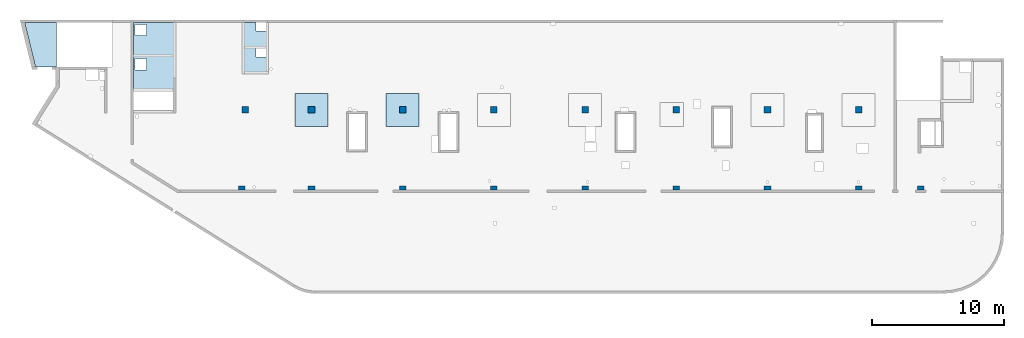
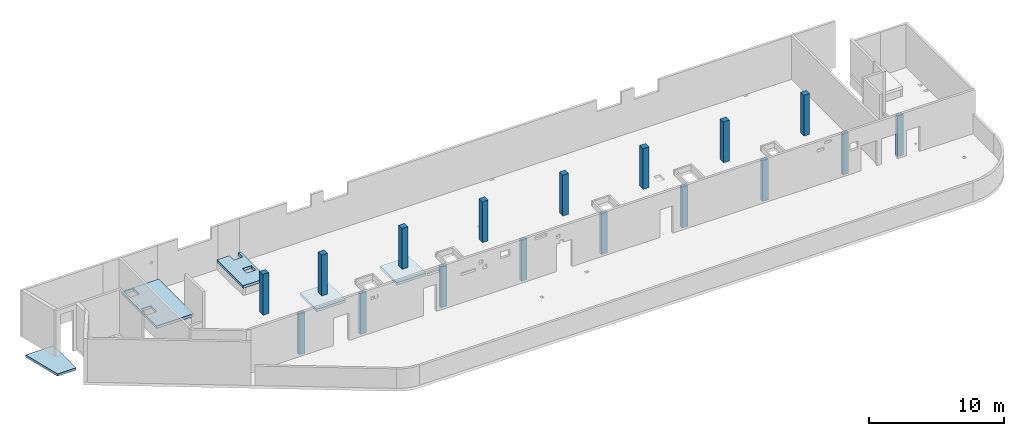
# One storey, part 1 of 6: 17 columns, 5 slabs.
"""IFC4 building model written with IfcOpenShell, lengths in millimetres."""

from ifc_helpers import new_model, entity, si_unit, converted_unit, derived_unit, direction, frame, origin, place, context, subcontext, project, spatial, indexed_curve, outline, extrude, source, transform, mapped, material, type_object, type_shapes, element, save


model = new_model("IFC4")

# Units and contexts
model_context = context("Model", 3, precision=0.01, world=origin(), true_north=direction((6.12303176911189e-17, 1.0)))
plan_context = context("Plan", 3, precision=0.01, world=origin(), true_north=direction((6.12303176911189e-17, 1.0)))
body_context = subcontext(model_context, "Body", "Model", "MODEL_VIEW")
ifc_project = project(units=[si_unit("LENGTHUNIT", "METRE", prefix="MILLI"), si_unit("AREAUNIT", "SQUARE_METRE"), si_unit("VOLUMEUNIT", "CUBIC_METRE"), converted_unit("PLANEANGLEUNIT", "DEGREE", entity("IfcRatioMeasure", 0.0174532925199433), si_unit("PLANEANGLEUNIT", "RADIAN"), dimensions=[0, 0, 0, 0, 0, 0, 0]), si_unit("MASSUNIT", "GRAM", prefix="KILO"), derived_unit("MASSDENSITYUNIT", [(si_unit("MASSUNIT", "GRAM", prefix="KILO"), 1), (si_unit("LENGTHUNIT", "METRE"), -3)]), derived_unit("MOMENTOFINERTIAUNIT", [(si_unit("LENGTHUNIT", "METRE"), 4)]), si_unit("TIMEUNIT", "SECOND"), si_unit("FREQUENCYUNIT", "HERTZ"), si_unit("THERMODYNAMICTEMPERATUREUNIT", "DEGREE_CELSIUS"), derived_unit("THERMALTRANSMITTANCEUNIT", [(si_unit("MASSUNIT", "GRAM", prefix="KILO"), 1), (si_unit("THERMODYNAMICTEMPERATUREUNIT", "KELVIN"), -1), (si_unit("TIMEUNIT", "SECOND"), -3)]), derived_unit("VOLUMETRICFLOWRATEUNIT", [(si_unit("LENGTHUNIT", "METRE"), 3), (si_unit("TIMEUNIT", "SECOND"), -1)]), derived_unit("MASSFLOWRATEUNIT", [(si_unit("MASSUNIT", "GRAM", prefix="KILO"), 1), (si_unit("TIMEUNIT", "SECOND"), -1)]), derived_unit("ROTATIONALFREQUENCYUNIT", [(si_unit("TIMEUNIT", "SECOND"), -1)]), si_unit("ELECTRICCURRENTUNIT", "AMPERE"), si_unit("ELECTRICVOLTAGEUNIT", "VOLT"), si_unit("POWERUNIT", "WATT"), si_unit("FORCEUNIT", "NEWTON", prefix="KILO"), si_unit("ILLUMINANCEUNIT", "LUX"), si_unit("LUMINOUSFLUXUNIT", "LUMEN"), si_unit("LUMINOUSINTENSITYUNIT", "CANDELA"), derived_unit("USERDEFINED", [(si_unit("MASSUNIT", "GRAM", prefix="KILO"), -1), (si_unit("LENGTHUNIT", "METRE"), -2), (si_unit("TIMEUNIT", "SECOND"), 3), (si_unit("LUMINOUSFLUXUNIT", "LUMEN"), 1)]), derived_unit("LINEARVELOCITYUNIT", [(si_unit("LENGTHUNIT", "METRE"), 1), (si_unit("TIMEUNIT", "SECOND"), -1)]), si_unit("PRESSUREUNIT", "PASCAL"), derived_unit("USERDEFINED", [(si_unit("LENGTHUNIT", "METRE"), -2), (si_unit("MASSUNIT", "GRAM", prefix="KILO"), 1), (si_unit("TIMEUNIT", "SECOND"), -2)]), derived_unit("LINEARFORCEUNIT", [(si_unit("MASSUNIT", "GRAM", prefix="KILO"), 1), (si_unit("LENGTHUNIT", "METRE"), 1), (si_unit("TIMEUNIT", "SECOND"), -2), (si_unit("LENGTHUNIT", "METRE"), -1)]), derived_unit("PLANARFORCEUNIT", [(si_unit("MASSUNIT", "GRAM", prefix="KILO"), 1), (si_unit("LENGTHUNIT", "METRE"), 1), (si_unit("TIMEUNIT", "SECOND"), -2), (si_unit("LENGTHUNIT", "METRE"), -2)])], contexts=[model_context, plan_context])

# Site, building, storey
site_placement = place(None, origin())
site = spatial("IfcSite", under=ifc_project, at=site_placement, CompositionType="ELEMENT")
building_placement = place(site_placement, origin())
building = spatial("IfcBuilding", under=site, at=building_placement, CompositionType="ELEMENT")
storey_placement = place(building_placement, frame((0.0, 0.0, 28200.0)))
storey = spatial("IfcBuildingStorey", under=building, at=storey_placement, Name="08", CompositionType="ELEMENT", Elevation=28200.0)

# Columns
ifc_material = material()
column_type_1 = type_object("IfcColumnType", PredefinedType="COLUMN", material=ifc_material)
shared_shape_1 = source(origin(), body_context, "Body", "SweptSolid", [
    extrude(outline(indexed_curve([(-149.999999999996, -249.999999999999), (149.999999999995, -249.999999999999), (149.999999999997, 249.999999999999), (-149.999999999997, 249.999999999999), (-149.999999999996, -249.999999999999)], self_intersect=False)), frame((15900.0, 7800.0, 28050.0), z_axis=(0.0, 0.0, 1.0), x_axis=(0.0, -1.0, 0.0)), (0.0, 0.0, 1.0), 3700.0),
])
type_shapes(column_type_1, [shared_shape_1])
placement_1 = place(storey_placement, frame((0.0, 0.0, -28200.0)))
element("IfcColumn", 1, at=placement_1, inside=storey, type_object=column_type_1, PredefinedType="COLUMN", context=body_context, shape_type="MappedRepresentation", body=[
    mapped(shared_shape_1, transform((0.0, 0.0, 0.0), scale=1.0)),
])
column_type_2 = type_object("IfcColumnType", PredefinedType="COLUMN", material=ifc_material)
shared_shape_2 = source(origin(), body_context, "Body", "SweptSolid", [
    extrude(outline(indexed_curve([(-149.999999999996, -249.999999999999), (149.999999999995, -249.999999999999), (149.999999999996, 249.999999999999), (-149.999999999997, 249.999999999999), (-149.999999999996, -249.999999999999)], self_intersect=False)), frame((21170.0, 7800.0, 28050.0), z_axis=(0.0, 0.0, 1.0), x_axis=(0.0, -1.0, 0.0)), (0.0, 0.0, 1.0), 3700.0),
])
type_shapes(column_type_2, [shared_shape_2])
element("IfcColumn", 2, at=placement_1, inside=storey, type_object=column_type_2, PredefinedType="COLUMN", context=body_context, shape_type="MappedRepresentation", body=[
    mapped(shared_shape_2, transform((0.0, 0.0, 0.0), scale=1.0)),
])
column_type_3 = type_object("IfcColumnType", PredefinedType="COLUMN", material=ifc_material)
shared_shape_3 = source(origin(), body_context, "Body", "SweptSolid", [
    extrude(outline(indexed_curve([(-149.999999999996, -249.999999999999), (149.999999999995, -249.999999999999), (149.999999999996, 249.999999999999), (-149.999999999996, 249.999999999999), (-149.999999999996, -249.999999999999)], self_intersect=False)), frame((28070.0, 7800.0, 28050.0), z_axis=(0.0, 0.0, 1.0), x_axis=(0.0, -1.0, 0.0)), (0.0, 0.0, 1.0), 3700.0),
])
type_shapes(column_type_3, [shared_shape_3])
element("IfcColumn", 3, at=placement_1, inside=storey, type_object=column_type_3, PredefinedType="COLUMN", context=body_context, shape_type="MappedRepresentation", body=[
    mapped(shared_shape_3, transform((0.0, 0.0, 0.0), scale=1.0)),
])
column_type_4 = type_object("IfcColumnType", PredefinedType="COLUMN", material=ifc_material)
shared_shape_4 = source(origin(), body_context, "Body", "SweptSolid", [
    extrude(outline(indexed_curve([(-149.999999999994, -249.999999999999), (149.999999999995, -249.999999999999), (149.999999999996, 249.999999999995), (-149.999999999995, 249.999999999999), (-149.999999999994, -249.999999999999)], self_intersect=False)), frame((34970.0, 7800.0, 28050.0), z_axis=(0.0, 0.0, 1.0), x_axis=(0.0, -1.0, 0.0)), (0.0, 0.0, 1.0), 3700.0),
])
type_shapes(column_type_4, [shared_shape_4])
element("IfcColumn", 4, at=placement_1, inside=storey, type_object=column_type_4, PredefinedType="COLUMN", context=body_context, shape_type="MappedRepresentation", body=[
    mapped(shared_shape_4, transform((0.0, 0.0, 0.0), scale=1.0)),
])
column_type_5 = type_object("IfcColumnType", PredefinedType="COLUMN", material=ifc_material)
shared_shape_5 = source(origin(), body_context, "Body", "SweptSolid", [
    extrude(outline(indexed_curve([(-149.999999999994, -250.000000000004), (149.999999999995, -250.000000000004), (149.999999999996, 250.000000000004), (-149.999999999994, 250.000000000004), (-149.999999999994, -250.000000000004)], self_intersect=False)), frame((41870.0, 7800.0, 28050.0), z_axis=(0.0, 0.0, 1.0), x_axis=(0.0, -1.0, 0.0)), (0.0, 0.0, 1.0), 3700.0),
])
type_shapes(column_type_5, [shared_shape_5])
element("IfcColumn", 5, at=placement_1, inside=storey, type_object=column_type_5, PredefinedType="COLUMN", context=body_context, shape_type="MappedRepresentation", body=[
    mapped(shared_shape_5, transform((0.0, 0.0, 0.0), scale=1.0)),
])
column_type_6 = type_object("IfcColumnType", PredefinedType="COLUMN", material=ifc_material)
shared_shape_6 = source(origin(), body_context, "Body", "SweptSolid", [
    extrude(outline(indexed_curve([(-149.999999999994, -250.000000000004), (149.999999999993, -250.000000000004), (149.999999999994, 250.000000000004), (-149.999999999995, 250.000000000004), (-149.999999999994, -250.000000000004)], self_intersect=False)), frame((48770.0, 7800.0, 28050.0), z_axis=(0.0, 0.0, 1.0), x_axis=(0.0, -1.0, 0.0)), (0.0, 0.0, 1.0), 3700.0),
])
type_shapes(column_type_6, [shared_shape_6])
element("IfcColumn", 6, at=placement_1, inside=storey, type_object=column_type_6, PredefinedType="COLUMN", context=body_context, shape_type="MappedRepresentation", body=[
    mapped(shared_shape_6, transform((0.0, 0.0, 0.0), scale=1.0)),
])
column_type_7 = type_object("IfcColumnType", PredefinedType="COLUMN", material=ifc_material)
shared_shape_7 = source(origin(), body_context, "Body", "SweptSolid", [
    extrude(outline(indexed_curve([(-149.999999999994, -250.000000000004), (149.999999999993, -250.000000000004), (149.999999999994, 250.000000000004), (-149.999999999994, 250.000000000004), (-149.999999999994, -250.000000000004)], self_intersect=False)), frame((55670.0, 7800.0, 28050.0), z_axis=(0.0, 0.0, 1.0), x_axis=(0.0, -1.0, 0.0)), (0.0, 0.0, 1.0), 3700.0),
])
type_shapes(column_type_7, [shared_shape_7])
element("IfcColumn", 7, at=placement_1, inside=storey, type_object=column_type_7, PredefinedType="COLUMN", context=body_context, shape_type="MappedRepresentation", body=[
    mapped(shared_shape_7, transform((0.0, 0.0, 0.0), scale=1.0)),
])
column_type_8 = type_object("IfcColumnType", PredefinedType="COLUMN", material=ifc_material)
shared_shape_8 = source(origin(), body_context, "Body", "SweptSolid", [
    extrude(outline(indexed_curve([(-149.999999999992, -250.000000000004), (149.999999999993, -250.000000000004), (149.999999999995, 250.000000000004), (-149.999999999993, 250.000000000004), (-149.999999999992, -250.000000000004)], self_intersect=False)), frame((62570.0, 7800.0, 28050.0), z_axis=(0.0, 0.0, 1.0), x_axis=(0.0, -1.0, 0.0)), (0.0, 0.0, 1.0), 3700.0),
])
type_shapes(column_type_8, [shared_shape_8])
element("IfcColumn", 8, at=placement_1, inside=storey, type_object=column_type_8, PredefinedType="COLUMN", context=body_context, shape_type="MappedRepresentation", body=[
    mapped(shared_shape_8, transform((0.0, 0.0, 0.0), scale=1.0)),
])
column_type_9 = type_object("IfcColumnType", PredefinedType="COLUMN", material=ifc_material)
shared_shape_9 = source(origin(), body_context, "Body", "SweptSolid", [
    extrude(outline(indexed_curve([(-149.999999999992, -250.000000000004), (149.999999999993, -250.000000000004), (149.999999999994, 250.000000000004), (-149.999999999993, 250.000000000004), (-149.999999999992, -250.000000000004)], self_intersect=False)), frame((67270.0, 7800.0, 28050.0), z_axis=(0.0, 0.0, 1.0), x_axis=(0.0, -1.0, 0.0)), (0.0, 0.0, 1.0), 3700.0),
])
type_shapes(column_type_9, [shared_shape_9])
element("IfcColumn", 9, at=placement_1, inside=storey, type_object=column_type_9, PredefinedType="COLUMN", context=body_context, shape_type="MappedRepresentation", body=[
    mapped(shared_shape_9, transform((0.0, 0.0, 0.0), scale=1.0)),
])
column_type_10 = type_object("IfcColumnType", PredefinedType="COLUMN", material=ifc_material)
shared_shape_10 = source(origin(), body_context, "Body", "SweptSolid", [
    extrude(outline(indexed_curve([(-249.999999999999, -250.000000000004), (249.999999999999, -250.000000000004), (249.999999999999, 249.999999999995), (-249.999999999999, 250.000000000004), (-249.999999999999, -250.000000000004)], self_intersect=False)), frame((62570.0, 13700.0, 28050.0), z_axis=(0.0, 0.0, 1.0), x_axis=(0.0, -1.0, 0.0)), (0.0, 0.0, 1.0), 3700.0),
])
type_shapes(column_type_10, [shared_shape_10])
element("IfcColumn", 10, at=placement_1, inside=storey, type_object=column_type_10, PredefinedType="COLUMN", context=body_context, shape_type="MappedRepresentation", body=[
    mapped(shared_shape_10, transform((0.0, 0.0, 0.0), scale=1.0)),
])
column_type_11 = type_object("IfcColumnType", PredefinedType="COLUMN", material=ifc_material)
shared_shape_11 = source(origin(), body_context, "Body", "SweptSolid", [
    extrude(outline(indexed_curve([(-249.999999999999, -250.000000000004), (249.999999999999, -250.000000000004), (249.999999999999, 249.999999999995), (-249.999999999999, 250.000000000004), (-249.999999999999, -250.000000000004)], self_intersect=False)), frame((55670.0, 13700.0, 28050.0), z_axis=(0.0, 0.0, 1.0), x_axis=(0.0, -1.0, 0.0)), (0.0, 0.0, 1.0), 3700.0),
])
type_shapes(column_type_11, [shared_shape_11])
element("IfcColumn", 11, at=placement_1, inside=storey, type_object=column_type_11, PredefinedType="COLUMN", context=body_context, shape_type="MappedRepresentation", body=[
    mapped(shared_shape_11, transform((0.0, 0.0, 0.0), scale=1.0)),
])
column_type_12 = type_object("IfcColumnType", PredefinedType="COLUMN", material=ifc_material)
shared_shape_12 = source(origin(), body_context, "Body", "SweptSolid", [
    extrude(outline(indexed_curve([(-249.999999999999, -250.000000000004), (249.999999999999, -250.000000000004), (249.999999999999, 249.999999999995), (-249.999999999999, 250.000000000004), (-249.999999999999, -250.000000000004)], self_intersect=False)), frame((48770.0, 13700.0, 28050.0), z_axis=(0.0, 0.0, 1.0), x_axis=(0.0, -1.0, 0.0)), (0.0, 0.0, 1.0), 3700.0),
])
type_shapes(column_type_12, [shared_shape_12])
element("IfcColumn", 12, at=placement_1, inside=storey, type_object=column_type_12, PredefinedType="COLUMN", context=body_context, shape_type="MappedRepresentation", body=[
    mapped(shared_shape_12, transform((0.0, 0.0, 0.0), scale=1.0)),
])
column_type_13 = type_object("IfcColumnType", PredefinedType="COLUMN", material=ifc_material)
shared_shape_13 = source(origin(), body_context, "Body", "SweptSolid", [
    extrude(outline(indexed_curve([(-249.999999999999, -250.000000000004), (249.999999999999, -250.000000000004), (249.999999999999, 249.999999999995), (-249.999999999999, 250.000000000004), (-249.999999999999, -250.000000000004)], self_intersect=False)), frame((41870.0, 13700.0, 28050.0), z_axis=(0.0, 0.0, 1.0), x_axis=(0.0, -1.0, 0.0)), (0.0, 0.0, 1.0), 3700.0),
])
type_shapes(column_type_13, [shared_shape_13])
element("IfcColumn", 13, at=placement_1, inside=storey, type_object=column_type_13, PredefinedType="COLUMN", context=body_context, shape_type="MappedRepresentation", body=[
    mapped(shared_shape_13, transform((0.0, 0.0, 0.0), scale=1.0)),
])
column_type_14 = type_object("IfcColumnType", PredefinedType="COLUMN", material=ifc_material)
shared_shape_14 = source(origin(), body_context, "Body", "SweptSolid", [
    extrude(outline(indexed_curve([(-249.999999999999, -249.999999999999), (249.999999999999, -249.999999999999), (249.999999999999, 249.999999999999), (-249.999999999999, 249.999999999999), (-249.999999999999, -249.999999999999)], self_intersect=False)), frame((34970.0, 13700.0, 28050.0), z_axis=(0.0, 0.0, 1.0), x_axis=(0.0, -1.0, 0.0)), (0.0, 0.0, 1.0), 3700.0),
])
type_shapes(column_type_14, [shared_shape_14])
element("IfcColumn", 14, at=placement_1, inside=storey, type_object=column_type_14, PredefinedType="COLUMN", context=body_context, shape_type="MappedRepresentation", body=[
    mapped(shared_shape_14, transform((0.0, 0.0, 0.0), scale=1.0)),
])
column_type_15 = type_object("IfcColumnType", PredefinedType="COLUMN", material=ifc_material)
shared_shape_15 = source(origin(), body_context, "Body", "SweptSolid", [
    extrude(outline(indexed_curve([(-249.999999999999, -249.999999999999), (249.999999999999, -249.999999999999), (249.999999999999, 249.999999999999), (-249.999999999999, 249.999999999999), (-249.999999999999, -249.999999999999)], self_intersect=False)), frame((28070.0, 13700.0, 28050.0), z_axis=(0.0, 0.0, 1.0), x_axis=(0.0, -1.0, 0.0)), (0.0, 0.0, 1.0), 3700.0),
])
type_shapes(column_type_15, [shared_shape_15])
element("IfcColumn", 15, at=placement_1, inside=storey, type_object=column_type_15, PredefinedType="COLUMN", context=body_context, shape_type="MappedRepresentation", body=[
    mapped(shared_shape_15, transform((0.0, 0.0, 0.0), scale=1.0)),
])
column_type_16 = type_object("IfcColumnType", PredefinedType="COLUMN", material=ifc_material)
shared_shape_16 = source(origin(), body_context, "Body", "SweptSolid", [
    extrude(outline(indexed_curve([(-249.999999999999, -249.999999999999), (249.999999999999, -249.999999999999), (249.999999999999, 249.999999999999), (-249.999999999999, 249.999999999999), (-249.999999999999, -249.999999999999)], self_intersect=False)), frame((21170.0, 13700.0, 28050.0), z_axis=(0.0, 0.0, 1.0), x_axis=(0.0, -1.0, 0.0)), (0.0, 0.0, 1.0), 3700.0),
])
type_shapes(column_type_16, [shared_shape_16])
element("IfcColumn", 16, at=placement_1, inside=storey, type_object=column_type_16, PredefinedType="COLUMN", context=body_context, shape_type="MappedRepresentation", body=[
    mapped(shared_shape_16, transform((0.0, 0.0, 0.0), scale=1.0)),
])
column_type_17 = type_object("IfcColumnType", PredefinedType="COLUMN", material=ifc_material)
shared_shape_17 = source(origin(), body_context, "Body", "SweptSolid", [
    extrude(outline(indexed_curve([(-249.999999999999, -249.999999999999), (249.999999999999, -249.999999999999), (249.999999999999, 249.999999999999), (-249.999999999999, 249.999999999999), (-249.999999999999, -249.999999999999)], self_intersect=False)), frame((16150.0, 13700.0, 28050.0), z_axis=(0.0, 0.0, 1.0), x_axis=(0.0, -1.0, 0.0)), (0.0, 0.0, 1.0), 3700.0),
])
type_shapes(column_type_17, [shared_shape_17])
element("IfcColumn", 17, at=placement_1, inside=storey, type_object=column_type_17, PredefinedType="COLUMN", context=body_context, shape_type="MappedRepresentation", body=[
    mapped(shared_shape_17, transform((0.0, 0.0, 0.0), scale=1.0)),
])

# Slabs
slab_type_1 = type_object("IfcSlabType", Name=":ADSK_ 25_250", PredefinedType="FLOOR", material=ifc_material)
placement_2 = place(storey_placement, origin())
element("IfcSlab", 18, at=placement_2, inside=storey, type_object=slab_type_1, material=ifc_material, Name=":ADSK_ 25_250", ObjectType=":ADSK_ 25_250", PredefinedType="FLOOR", context=body_context, shape_type="SweptSolid", body=[
    extrude(outline(indexed_curve([(-1640.0, -2980.0000639367), (-1439.99999999999, -2980.0000639367), (1559.99999999999, -2980.0000639367), (1559.99999999999, -580.000063936673), (1559.99999999999, -380.000063936673), (1559.99999999999, 2019.99993606334), (1559.99999999999, 2219.99993606334), (-1439.99999999999, 2219.99993606334), (-1640.0, 2219.99993606334), (-1640.0, 1220.00057543014), (-1640.0, -2980.0000639367)], self_intersect=False), holes=[indexed_curve([(585.0, -255.000063936664), (585.0, 594.999936063335), (1435.0, 594.999936063335), (1435.0, -255.000063936664), (585.0, -255.000063936664)], self_intersect=False), indexed_curve([(584.999999999996, -2855.00006393667), (584.999999999996, -2005.00006393667), (1435.0, -2005.00006393667), (1435.0, -2855.00006393667), (584.999999999996, -2855.00006393667)], self_intersect=False)]), frame((9260.0, 17320.0, 500.0), z_axis=(0.0, 0.0, 1.0), x_axis=(-1.0, 0.0, 0.0)), (0.0, 0.0, 1.0), 249.999999999999),
])
slab_type_2 = type_object("IfcSlabType", Name=":ADSK_ 25_250", PredefinedType="FLOOR", material=ifc_material)
element("IfcSlab", 19, at=placement_2, inside=storey, type_object=slab_type_2, material=ifc_material, Name=":ADSK_ 25_250", ObjectType=":ADSK_ 25_250", PredefinedType="FLOOR", context=body_context, shape_type="SweptSolid", body=[
    extrude(outline(indexed_curve([(-913.636363636355, -1518.18216692726), (-713.636363636364, -1518.18216692726), (-713.636363636364, -868.181527560958), (61.3636363636352, -868.181527560958), (61.3636363636352, -1518.18216692726), (911.363636363622, -1518.18216692726), (1111.36363636363, -1518.18216692726), (1111.36363636363, 2381.81847243956), (911.363636363628, 2381.81847243956), (-913.636363636355, 2381.81847243956), (-913.636363636355, 2181.81847243956), (-913.636363636355, -1518.18216692726)], self_intersect=False), holes=[indexed_curve([(-713.636363636362, 431.817833072721), (-713.636363636362, 1081.81783307272), (61.3636363636374, 1081.81783307272), (61.3636363636374, 431.817833072721), (-713.636363636362, 431.817833072721)], self_intersect=False)]), frame((17011.36, 18781.82, 500.0), z_axis=(0.0, 0.0, 1.0), x_axis=(-1.0, 0.0, 0.0)), (0.0, 0.0, 1.0), 249.999999999999),
])
slab_type_3 = type_object("IfcSlabType", Name=":ADSK_ 25_200", PredefinedType="FLOOR", material=ifc_material)
element("IfcSlab", 20, at=placement_2, inside=storey, type_object=slab_type_3, material=ifc_material, Name=":ADSK_ 25_200", ObjectType=":ADSK_ 25_200", PredefinedType="FLOOR", context=body_context, shape_type="SweptSolid", body=[
    extrude(outline(indexed_curve([(-998.540084126058, -1670.00000000026), (591.459915873942, -1670.00000000026), (1405.62025237818, 1670.00000000027), (-998.540084126064, 1670.00000000026), (-998.540084126058, -1670.00000000026)], self_intersect=False)), frame((870.78, 18630.0, -2130.0), z_axis=(0.0, 0.0, -1.0), x_axis=(-1.0, 0.0, 0.0)), (0.0, 0.0, 1.0), 199.999999999998),
])
slab_type_4 = type_object("IfcSlabType", Name=":ADSK_ 25_250", PredefinedType="FLOOR", material=ifc_material)
element("IfcSlab", 21, at=placement_2, inside=storey, type_object=slab_type_4, material=ifc_material, Name=":ADSK_ 25_250", ObjectType=":ADSK_ 25_250", PredefinedType="FLOOR", context=body_context, shape_type="SweptSolid", body=[
    extrude(outline(indexed_curve([(-1250.0, -1250.0), (1250.0, -1250.0), (1250.0, 1250.0), (-1250.0, 1250.0), (-1250.0, -1250.0)], self_intersect=False)), frame((21170.0, 13700.0, -400.0), z_axis=(0.0, 0.0, -1.0), x_axis=(0.0, 1.0, 0.0)), (0.0, 0.0, 1.0), 249.999999999999),
])
slab_type_5 = type_object("IfcSlabType", Name=":ADSK_ 25_250", PredefinedType="FLOOR", material=ifc_material)
element("IfcSlab", 22, at=placement_2, inside=storey, type_object=slab_type_5, material=ifc_material, Name=":ADSK_ 25_250", ObjectType=":ADSK_ 25_250", PredefinedType="FLOOR", context=body_context, shape_type="SweptSolid", body=[
    extrude(outline(indexed_curve([(-1250.0, -1250.0), (1250.0, -1250.0), (1250.0, 1250.0), (-1250.0, 1250.0), (-1250.0, -1250.0)], self_intersect=False)), frame((28070.0, 13700.0, -400.0), z_axis=(0.0, 0.0, -1.0), x_axis=(0.0, 1.0, 0.0)), (0.0, 0.0, 1.0), 249.999999999999),
])

save(model, "model.ifc")
